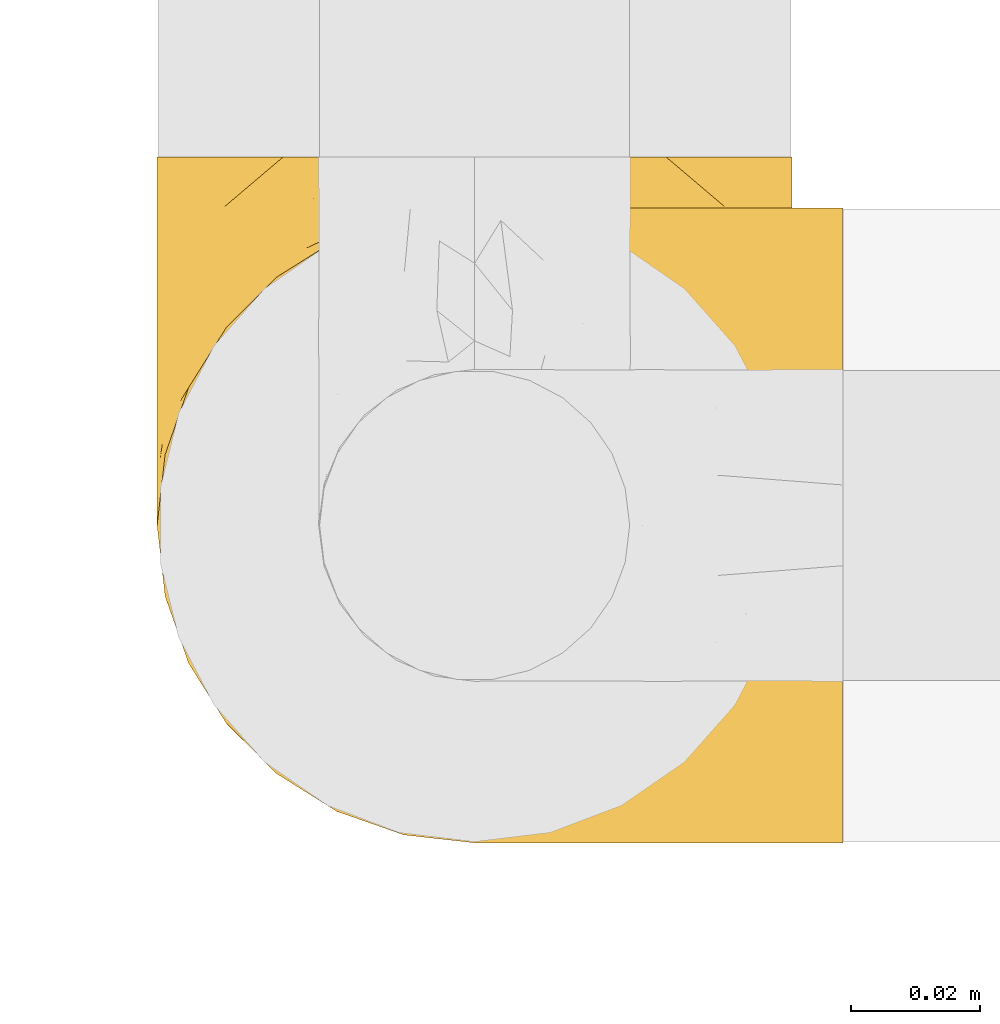
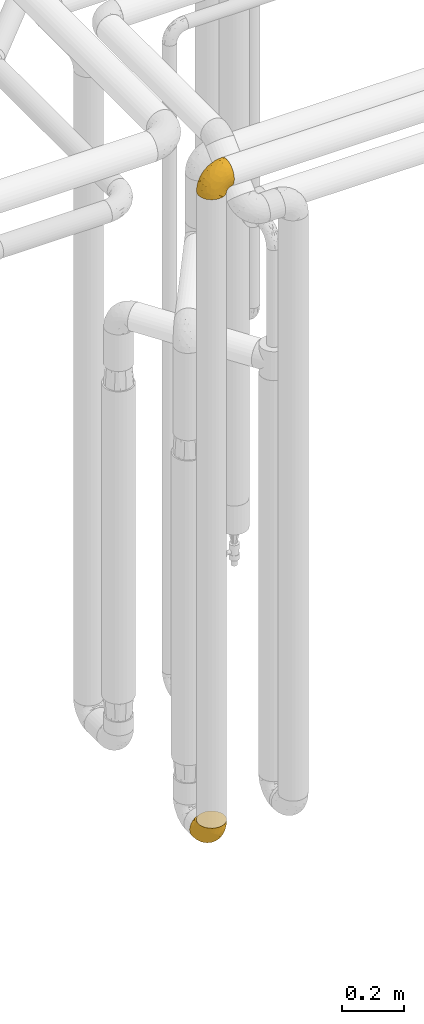
# One storey, part 381 of 827: 2 coverings.
"""IFC2X3 building model written with IfcOpenShell, lengths in millimetres."""

from ifc_helpers import new_model, entity, si_unit, converted_unit, derived_unit, direction, frame, origin, place, context, subcontext, project, spatial, faceted_brep, element, save


model = new_model("IFC2X3")

# Units and contexts
model_context = context("Model", 3, precision=0.01, world=origin(), true_north=direction((6.12303176911189e-17, 1.0)))
body_context = subcontext(model_context, "Body", "Model", "MODEL_VIEW")
ifc_project = project(units=[si_unit("LENGTHUNIT", "METRE", prefix="MILLI"), si_unit("AREAUNIT", "SQUARE_METRE"), si_unit("VOLUMEUNIT", "CUBIC_METRE"), converted_unit("PLANEANGLEUNIT", "DEGREE", entity("IfcRatioMeasure", 0.0174532925199433), si_unit("PLANEANGLEUNIT", "RADIAN"), dimensions=[0, 0, 0, 0, 0, 0, 0]), si_unit("MASSUNIT", "GRAM", prefix="KILO"), derived_unit("MASSDENSITYUNIT", [(si_unit("MASSUNIT", "GRAM", prefix="KILO"), 1), (si_unit("LENGTHUNIT", "METRE"), -3)]), derived_unit("MOMENTOFINERTIAUNIT", [(si_unit("LENGTHUNIT", "METRE"), 4)]), si_unit("TIMEUNIT", "SECOND"), si_unit("FREQUENCYUNIT", "HERTZ"), si_unit("THERMODYNAMICTEMPERATUREUNIT", "DEGREE_CELSIUS"), derived_unit("THERMALTRANSMITTANCEUNIT", [(si_unit("MASSUNIT", "GRAM", prefix="KILO"), 1), (si_unit("THERMODYNAMICTEMPERATUREUNIT", "KELVIN"), -1), (si_unit("TIMEUNIT", "SECOND"), -3)]), derived_unit("VOLUMETRICFLOWRATEUNIT", [(si_unit("LENGTHUNIT", "METRE"), 3), (si_unit("TIMEUNIT", "SECOND"), -1)]), derived_unit("MASSFLOWRATEUNIT", [(si_unit("MASSUNIT", "GRAM", prefix="KILO"), 1), (si_unit("TIMEUNIT", "SECOND"), -1)]), derived_unit("ROTATIONALFREQUENCYUNIT", [(si_unit("TIMEUNIT", "SECOND"), -1)]), si_unit("ELECTRICCURRENTUNIT", "AMPERE"), si_unit("ELECTRICVOLTAGEUNIT", "VOLT"), si_unit("POWERUNIT", "WATT"), si_unit("FORCEUNIT", "NEWTON", prefix="KILO"), si_unit("ILLUMINANCEUNIT", "LUX"), si_unit("LUMINOUSFLUXUNIT", "LUMEN"), si_unit("LUMINOUSINTENSITYUNIT", "CANDELA"), derived_unit("USERDEFINED", [(si_unit("MASSUNIT", "GRAM", prefix="KILO"), -1), (si_unit("LENGTHUNIT", "METRE"), -2), (si_unit("TIMEUNIT", "SECOND"), 3), (si_unit("LUMINOUSFLUXUNIT", "LUMEN"), 1)]), derived_unit("LINEARVELOCITYUNIT", [(si_unit("LENGTHUNIT", "METRE"), 1), (si_unit("TIMEUNIT", "SECOND"), -1)]), si_unit("PRESSUREUNIT", "PASCAL"), derived_unit("USERDEFINED", [(si_unit("LENGTHUNIT", "METRE"), -2), (si_unit("MASSUNIT", "GRAM", prefix="KILO"), 1), (si_unit("TIMEUNIT", "SECOND"), -2)]), derived_unit("LINEARFORCEUNIT", [(si_unit("MASSUNIT", "GRAM", prefix="KILO"), 1), (si_unit("LENGTHUNIT", "METRE"), 1), (si_unit("TIMEUNIT", "SECOND"), -2), (si_unit("LENGTHUNIT", "METRE"), -1)]), derived_unit("PLANARFORCEUNIT", [(si_unit("MASSUNIT", "GRAM", prefix="KILO"), 1), (si_unit("LENGTHUNIT", "METRE"), 1), (si_unit("TIMEUNIT", "SECOND"), -2), (si_unit("LENGTHUNIT", "METRE"), -2)])], contexts=[model_context])

# Site, building, storey
site_placement = place(None, origin())
site = spatial("IfcSite", under=ifc_project, at=site_placement, CompositionType="ELEMENT")
building_placement = place(site_placement, origin())
building = spatial("IfcBuilding", under=site, at=building_placement, CompositionType="ELEMENT")
storey_placement = place(building_placement, frame((0.0, 0.0, 28200.0)))
storey = spatial("IfcBuildingStorey", under=building, at=storey_placement, Name="08", CompositionType="ELEMENT", Elevation=28200.0)

# Coverings
covering_1_placement = place(storey_placement, frame((46642.04, 13586.09, 2941.4)))
element("IfcCovering", 1, at=covering_1_placement, inside=storey, Name=":ADSK_", ObjectType=":ADSK_", PredefinedType="INSULATION", context=body_context, shape_type="Brep", body=[
    faceted_brep([(50.75, 1.6, 1.6), (39.8, 2.83, 1.6), (29.41, 6.47, 1.6), (20.09, 12.32, 1.6), (12.31, 20.11, 1.6), (6.46, 29.43, 1.6), (2.83, 39.81, 1.6), (1.6, 50.75, 1.6), (2.83, 61.69, 1.6), (6.47, 72.08, 1.6), (12.32, 81.4, 1.6), (20.11, 89.18, 1.6), (29.43, 95.03, 1.6), (39.81, 98.66, 1.6), (50.75, 99.9, 1.6), (56.45, 99.25, 1.6), (61.69, 98.66, 1.6), (66.88, 96.84, 1.6), (72.08, 95.02, 1.6), (81.4, 89.17, 1.6), (89.18, 81.38, 1.6), (95.03, 72.06, 1.6), (98.66, 61.68, 1.6), (99.9, 50.75, 1.6), (98.66, 39.8, 1.6), (95.02, 29.41, 1.6), (89.17, 20.09, 1.6), (81.38, 12.31, 1.6), (72.06, 6.46, 1.6), (66.87, 4.64, 1.6), (61.68, 2.83, 1.6), (56.45, 2.24, 1.6), (53.6, 1.92, 1.6), (107.75, 63.47, 11.12), (107.75, 75.32, 16.03), (107.75, 80.41, 19.94), (107.75, 85.5, 23.84), (107.75, 89.4, 28.93), (107.75, 93.31, 34.02), (107.75, 95.77, 39.95), (107.75, 98.22, 45.87), (107.75, 99.14, 52.86), (107.75, 99.52, 55.73), (107.75, 99.9, 58.6), (107.75, 98.22, 71.32), (107.75, 93.31, 83.17), (107.75, 85.5, 93.35), (107.75, 75.32, 101.16), (107.75, 63.47, 106.07), (107.75, 50.75, 107.75), (107.75, 38.02, 106.07), (107.75, 26.17, 101.16), (107.75, 15.99, 93.35), (107.75, 8.18, 83.17), (107.75, 3.27, 71.32), (107.75, 1.6, 58.6), (107.75, 2.35, 52.86), (107.75, 3.27, 45.87), (107.75, 5.73, 39.95), (107.75, 8.18, 34.02), (107.75, 12.09, 28.93), (107.75, 15.99, 23.84), (107.75, 21.08, 19.94), (107.75, 26.17, 16.03), (107.75, 38.02, 11.12), (107.75, 50.75, 9.45), (39.38, 42.18, 81.82), (49.75, 28.42, 84.02), (57.38, 37.78, 93.05), (74.94, 50.75, 102.55), (85.97, 42.85, 104.83), (95.66, 50.75, 105.83), (67.82, 24.75, 91.87), (83.09, 33.81, 101.74), (89.16, 22.57, 97.07), (37.01, 7.18, 38.45), (43.46, 2.73, 22.17), (51.79, 3.09, 42.04), (85.58, 6.92, 77.69), (62.84, 11.58, 75.76), (62.77, 5.17, 62.11), (88.17, 2.71, 66.08), (85.93, 1.6, 54.26), (91.42, 1.6, 55.35), (96.91, 1.6, 56.44), (99.62, 1.6, 56.98), (102.33, 1.6, 57.52), (82.57, 14.18, 87.84), (32.75, 5.88, 19.41), (13.79, 41.06, 48.89), (6.77, 36.25, 26.34), (16.46, 28.62, 44.55), (55.08, 1.6, 23.41), (58.17, 1.6, 28.03), (61.26, 1.6, 32.65), (64.35, 1.6, 37.28), (67.44, 1.6, 41.9), (24.18, 10.85, 20.6), (23.37, 38.35, 63.36), (49.76, 9.6, 62.21), (9.84, 26.24, 19.94), (3.51, 50.75, 13.68), (55.75, 19.31, 80.85), (42.34, 16.41, 66.53), (37.78, 24.56, 71.06), (21.87, 50.75, 63.99), (33.61, 50.75, 75.73), (17.1, 18.47, 26.77), (51.28, 1.6, 4.31), (51.82, 1.6, 7.01), (52.9, 1.6, 12.43), (53.99, 1.6, 17.92), (28.01, 14.36, 43.43), (28.99, 20.64, 56.23), (69.9, 2.32, 54.97), (6.79, 50.75, 34.4), (72.06, 1.6, 44.99), (76.69, 1.6, 48.08), (81.31, 1.6, 51.17), (45.35, 50.75, 87.47), (34.79, 33.88, 74.55), (25.72, 29.24, 60.86), (14.33, 50.75, 49.19), (60.15, 50.75, 95.01), (62.38, 2.8, 10.27), (100.57, 2.48, 48.79), (91.06, 2.7, 45.16), (97.66, 3.2, 44.99), (97.55, 32.98, 6.17), (93.65, 24.67, 7.65), (66.85, 2.95, 21.59), (61.93, 2.19, 19.96), (101.4, 17.92, 21.0), (100.07, 12.02, 27.2), (101.36, 25.73, 14.83), (95.94, 16.63, 19.7), (96.3, 25.6, 10.93), (101.98, 36.72, 9.63), (85.88, 10.66, 19.97), (78.88, 6.87, 21.13), (82.8, 11.12, 14.14), (102.58, 10.31, 30.2), (82.88, 12.84, 8.12), (88.57, 17.38, 9.93), (88.67, 9.74, 24.62), (69.08, 4.63, 11.87), (102.19, 50.75, 7.15), (100.06, 42.52, 5.32), (70.56, 3.12, 26.68), (91.07, 17.58, 13.92), (77.56, 3.97, 30.67), (96.59, 5.94, 36.65), (86.38, 2.73, 42.89), (91.79, 6.23, 34.04), (81.71, 3.45, 36.6), (94.11, 10.84, 26.41), (76.09, 7.98, 10.07), (76.91, 7.33, 15.83), (81.44, 2.39, 41.99), (101.37, 75.76, 14.83), (94.12, 90.65, 26.4), (101.41, 83.57, 21.01), (95.96, 84.85, 19.71), (96.22, 71.05, 5.72), (66.85, 98.54, 21.6), (61.94, 99.3, 19.96), (58.17, 99.9, 28.03), (69.1, 96.86, 11.87), (88.58, 84.1, 9.93), (96.91, 99.9, 56.44), (102.33, 99.9, 57.52), (105.04, 99.9, 58.06), (82.9, 88.63, 8.13), (82.82, 90.36, 14.15), (97.66, 98.29, 44.99), (96.59, 95.55, 36.65), (100.07, 89.47, 27.21), (91.79, 95.26, 34.04), (102.58, 91.18, 30.2), (76.13, 93.49, 10.06), (76.93, 94.15, 15.83), (100.57, 99.01, 48.79), (86.38, 98.76, 42.89), (90.86, 98.85, 45.38), (52.9, 99.9, 12.43), (62.39, 98.69, 10.28), (101.98, 64.78, 9.64), (91.42, 99.9, 55.35), (85.93, 99.9, 54.26), (99.49, 62.91, 6.05), (51.82, 99.9, 7.01), (52.36, 99.9, 9.72), (61.26, 99.9, 32.65), (70.56, 98.37, 26.68), (91.09, 83.9, 13.92), (64.35, 99.9, 37.28), (77.6, 97.51, 30.66), (78.89, 94.62, 21.14), (81.71, 98.04, 36.59), (88.69, 91.73, 24.6), (53.99, 99.9, 17.92), (55.08, 99.9, 23.41), (96.31, 75.87, 10.93), (85.9, 90.83, 19.97), (81.45, 99.1, 41.99), (76.69, 99.9, 48.08), (81.31, 99.9, 51.17), (72.06, 99.9, 44.99), (67.44, 99.9, 41.9), (69.6, 99.09, 55.26), (85.97, 58.64, 104.83), (82.57, 87.31, 87.84), (63.16, 89.93, 75.91), (55.81, 82.22, 80.84), (67.81, 76.74, 91.87), (49.73, 73.12, 83.98), (32.55, 95.54, 19.16), (43.23, 98.7, 22.37), (88.17, 98.79, 66.08), (57.38, 63.71, 93.05), (83.08, 67.68, 101.74), (89.16, 78.92, 97.07), (85.58, 94.57, 77.69), (16.46, 72.88, 44.55), (6.77, 65.25, 26.34), (13.8, 60.44, 48.9), (37.71, 76.94, 70.99), (34.8, 67.61, 74.55), (36.83, 94.38, 37.8), (39.38, 59.31, 81.82), (17.12, 83.03, 26.77), (24.19, 90.66, 20.6), (28.89, 80.8, 56.15), (25.69, 72.22, 60.85), (51.77, 98.39, 42.06), (45.66, 92.31, 57.03), (23.39, 63.11, 63.4), (9.85, 75.27, 19.94), (28.11, 87.15, 43.59), (62.27, 96.03, 62.61), (42.35, 85.1, 66.52)], [[[0, 1, 2, 3, 4, 5, 6, 7, 8, 9, 10, 11, 12, 13, 14, 15, 16, 17, 18, 19, 20, 21, 22, 23, 24, 25, 26, 27, 28, 29, 30, 31, 32]], [[33, 34, 35, 36, 37, 38, 39, 40, 41, 42, 43, 44, 45, 46, 47, 48, 49, 50, 51, 52, 53, 54, 55, 56, 57, 58, 59, 60, 61, 62, 63, 64, 65]], [[66, 67, 68]], [[69, 70, 71]], [[68, 72, 73]], [[73, 72, 74]], [[75, 76, 77]], [[78, 79, 80]], [[51, 50, 73]], [[81, 82, 83, 84, 85, 86, 55]], [[52, 87, 53]], [[74, 52, 51]], [[2, 1, 88]], [[89, 90, 91]], [[77, 92, 93, 94, 95, 96]], [[55, 54, 81]], [[78, 53, 87]], [[5, 90, 6]], [[88, 76, 75]], [[97, 3, 2]], [[89, 91, 98]], [[99, 80, 79]], [[90, 5, 100]], [[74, 87, 52]], [[100, 5, 4]], [[90, 101, 6]], [[79, 102, 103]], [[102, 67, 104]], [[105, 98, 106]], [[107, 4, 3]], [[76, 0, 108, 109, 110, 111, 92]], [[107, 112, 113]], [[114, 77, 96]], [[89, 115, 90]], [[114, 96, 116, 117, 118, 82]], [[75, 97, 88]], [[119, 66, 68]], [[50, 71, 70]], [[100, 91, 90]], [[99, 77, 80]], [[102, 104, 103]], [[97, 107, 3]], [[80, 81, 78]], [[107, 97, 112]], [[68, 73, 70]], [[66, 98, 120]], [[78, 81, 54]], [[114, 81, 80]], [[53, 78, 54]], [[78, 87, 79]], [[102, 87, 72]], [[79, 103, 99]], [[4, 107, 100]], [[91, 100, 107]], [[88, 97, 2]], [[112, 97, 75]], [[99, 112, 75]], [[103, 104, 113]], [[91, 121, 98]], [[89, 105, 122, 115]], [[101, 90, 115]], [[101, 7, 6]], [[88, 1, 76]], [[0, 76, 1]], [[92, 77, 76]], [[73, 74, 51]], [[87, 74, 72]], [[81, 114, 82]], [[77, 114, 80]], [[87, 102, 79]], [[67, 102, 72]], [[68, 67, 72]], [[67, 120, 104]], [[120, 121, 104]], [[104, 121, 113]], [[121, 120, 98]], [[91, 107, 113]], [[91, 113, 121]], [[103, 113, 112]], [[106, 98, 66]], [[105, 89, 98]], [[106, 66, 119]], [[67, 66, 120]], [[68, 69, 123, 119]], [[50, 49, 71]], [[50, 70, 73]], [[112, 99, 103]], [[77, 99, 75]], [[69, 68, 70]], [[29, 124, 110]], [[84, 83, 125]], [[126, 82, 118]], [[59, 58, 127]], [[25, 128, 129]], [[130, 93, 131]], [[132, 62, 133]], [[134, 135, 136]], [[137, 65, 64]], [[64, 134, 137]], [[138, 139, 140]], [[111, 110, 124, 92]], [[134, 136, 137]], [[134, 64, 63]], [[141, 61, 60]], [[125, 58, 57]], [[142, 143, 140]], [[142, 26, 143]], [[127, 83, 82]], [[28, 124, 29]], [[108, 0, 32, 31, 30, 110, 109]], [[30, 29, 110]], [[135, 144, 138]], [[28, 145, 124]], [[57, 56, 55, 86, 85, 84]], [[146, 147, 23]], [[24, 23, 147]], [[25, 143, 26]], [[95, 94, 148]], [[24, 128, 25]], [[149, 138, 143]], [[124, 145, 131]], [[127, 58, 125]], [[150, 148, 139]], [[127, 126, 151]], [[151, 59, 127]], [[152, 151, 126]], [[153, 154, 155]], [[153, 133, 141]], [[145, 28, 27]], [[142, 156, 27]], [[157, 148, 130]], [[61, 133, 62]], [[134, 132, 135]], [[147, 128, 24]], [[65, 137, 146]], [[146, 137, 147]], [[128, 137, 136]], [[137, 128, 147]], [[128, 136, 129]], [[149, 129, 136]], [[25, 129, 143]], [[158, 152, 117]], [[152, 118, 117]], [[153, 151, 152]], [[158, 116, 154]], [[144, 150, 138]], [[153, 152, 158]], [[133, 153, 155]], [[133, 155, 132]], [[60, 151, 141]], [[135, 132, 155]], [[134, 63, 132]], [[144, 135, 155]], [[135, 138, 149]], [[155, 154, 144]], [[150, 154, 96]], [[154, 150, 144]], [[148, 94, 130]], [[82, 126, 127]], [[118, 152, 126]], [[150, 96, 95]], [[139, 148, 157]], [[150, 95, 148]], [[93, 92, 131]], [[130, 145, 156]], [[130, 94, 93]], [[84, 125, 57]], [[127, 125, 83]], [[140, 139, 157]], [[150, 139, 138]], [[140, 157, 142]], [[138, 140, 143]], [[156, 142, 157]], [[27, 26, 142]], [[130, 156, 157]], [[145, 27, 156]], [[132, 63, 62]], [[124, 131, 92]], [[130, 131, 145]], [[129, 149, 143]], [[135, 149, 136]], [[141, 133, 61]], [[60, 59, 151]], [[141, 151, 153]], [[116, 96, 154]], [[153, 158, 154]], [[158, 117, 116]], [[34, 33, 159]], [[160, 161, 162]], [[22, 21, 163]], [[164, 165, 166]], [[19, 18, 167]], [[168, 21, 20]], [[42, 41, 40, 169, 170, 171, 43]], [[172, 173, 168]], [[174, 38, 175]], [[176, 177, 178]], [[179, 164, 180]], [[40, 181, 169]], [[182, 183, 175]], [[17, 184, 185]], [[65, 146, 186]], [[187, 174, 188]], [[23, 22, 189]], [[174, 39, 38]], [[15, 14, 190, 191, 184, 16]], [[181, 40, 39]], [[192, 193, 164]], [[194, 163, 168]], [[33, 186, 159]], [[180, 173, 172]], [[195, 196, 193]], [[18, 185, 167]], [[173, 180, 197]], [[198, 199, 196]], [[200, 201, 185, 184]], [[184, 17, 16]], [[18, 17, 185]], [[202, 159, 186]], [[194, 168, 203]], [[189, 163, 202]], [[204, 205, 182]], [[187, 181, 174]], [[160, 177, 176]], [[206, 183, 182]], [[206, 182, 205]], [[201, 165, 185]], [[165, 164, 167]], [[172, 179, 180]], [[202, 194, 162]], [[176, 161, 160]], [[65, 186, 33]], [[163, 189, 22]], [[175, 177, 182]], [[174, 183, 188]], [[177, 198, 204]], [[199, 160, 162]], [[198, 207, 204]], [[175, 38, 37]], [[198, 177, 160]], [[178, 177, 175]], [[176, 35, 161]], [[34, 159, 161]], [[162, 161, 159]], [[202, 162, 159]], [[199, 162, 203]], [[196, 199, 203]], [[198, 160, 199]], [[193, 197, 180]], [[208, 198, 196]], [[188, 183, 206]], [[175, 183, 174]], [[193, 192, 195]], [[195, 208, 196]], [[197, 196, 203]], [[180, 164, 193]], [[168, 163, 21]], [[166, 165, 201]], [[166, 192, 164]], [[189, 202, 186]], [[186, 146, 189]], [[23, 189, 146]], [[174, 181, 39]], [[169, 181, 187]], [[196, 197, 193]], [[173, 203, 168]], [[203, 173, 197]], [[172, 168, 20]], [[20, 19, 172]], [[179, 172, 19]], [[19, 167, 179]], [[164, 179, 167]], [[35, 176, 36]], [[35, 34, 161]], [[185, 165, 167]], [[162, 194, 203]], [[163, 194, 202]], [[176, 178, 36]], [[37, 36, 178]], [[175, 37, 178]], [[177, 204, 182]], [[207, 198, 208]], [[207, 205, 204]], [[209, 188, 206, 205, 207, 208]], [[48, 210, 71]], [[211, 212, 213]], [[214, 213, 215]], [[216, 217, 13]], [[218, 43, 171, 170, 169, 187, 188]], [[219, 220, 214]], [[47, 46, 221]], [[210, 48, 220]], [[211, 222, 212]], [[222, 45, 44]], [[221, 220, 47]], [[47, 220, 48]], [[221, 211, 214]], [[223, 224, 225]], [[211, 46, 45]], [[226, 227, 215]], [[43, 218, 44]], [[217, 216, 228]], [[219, 215, 229]], [[14, 13, 217]], [[224, 9, 8]], [[10, 230, 11]], [[11, 231, 12]], [[232, 223, 233]], [[234, 208, 195, 192, 166, 201]], [[235, 234, 228]], [[222, 44, 218]], [[106, 229, 236]], [[224, 237, 9]], [[231, 238, 228]], [[9, 237, 10]], [[115, 224, 101]], [[239, 234, 235]], [[231, 11, 230]], [[223, 230, 237]], [[224, 8, 101]], [[223, 236, 233]], [[225, 115, 122, 105]], [[216, 12, 231]], [[209, 234, 239]], [[210, 219, 69]], [[219, 214, 215]], [[229, 119, 219]], [[209, 218, 188]], [[239, 212, 222]], [[239, 222, 218]], [[45, 222, 211]], [[235, 212, 239]], [[213, 212, 240]], [[223, 237, 224]], [[230, 10, 237]], [[238, 231, 230]], [[216, 231, 228]], [[232, 230, 223]], [[235, 238, 240]], [[115, 225, 224]], [[233, 236, 227]], [[8, 7, 101]], [[234, 209, 208]], [[218, 209, 239]], [[217, 228, 234]], [[13, 12, 216]], [[234, 201, 217]], [[217, 201, 200, 184, 191, 190, 14]], [[211, 221, 46]], [[220, 221, 214]], [[71, 210, 69]], [[71, 49, 48]], [[219, 210, 220]], [[226, 215, 213]], [[211, 213, 214]], [[226, 213, 240]], [[215, 227, 229]], [[232, 240, 238]], [[233, 227, 226]], [[232, 233, 226]], [[236, 223, 225]], [[240, 232, 226]], [[232, 238, 230]], [[225, 105, 236]], [[236, 105, 106]], [[236, 229, 227]], [[123, 69, 219, 119]], [[106, 119, 229]], [[238, 235, 228]], [[212, 235, 240]]]),
])
covering_2_placement = place(storey_placement, frame((46642.04, 13586.09, 349.25)))
element("IfcCovering", 2, at=covering_2_placement, inside=storey, Name=":ADSK_", ObjectType=":ADSK_", PredefinedType="INSULATION", context=body_context, shape_type="Brep", body=[
    faceted_brep([(1.6, 50.75, 107.75), (2.83, 39.8, 107.75), (6.47, 29.41, 107.75), (12.32, 20.09, 107.75), (20.11, 12.31, 107.75), (29.43, 6.46, 107.75), (39.81, 2.83, 107.75), (50.75, 1.6, 107.75), (61.69, 2.83, 107.75), (72.08, 6.47, 107.75), (81.4, 12.32, 107.75), (89.18, 20.11, 107.75), (95.03, 29.43, 107.75), (98.66, 39.81, 107.75), (99.9, 50.75, 107.75), (99.25, 56.45, 107.75), (98.66, 61.69, 107.75), (96.84, 66.88, 107.75), (95.02, 72.08, 107.75), (89.17, 81.4, 107.75), (81.38, 89.18, 107.75), (72.06, 95.03, 107.75), (61.68, 98.66, 107.75), (50.75, 99.9, 107.75), (39.8, 98.66, 107.75), (29.41, 95.02, 107.75), (20.09, 89.17, 107.75), (12.31, 81.38, 107.75), (6.46, 72.06, 107.75), (4.64, 66.87, 107.75), (2.83, 61.68, 107.75), (2.24, 56.45, 107.75), (1.92, 53.6, 107.75), (63.47, 107.75, 98.22), (75.32, 107.75, 93.31), (80.41, 107.75, 89.4), (85.5, 107.75, 85.5), (89.4, 107.75, 80.41), (93.31, 107.75, 75.32), (95.77, 107.75, 69.39), (98.22, 107.75, 63.47), (99.14, 107.75, 56.48), (99.52, 107.75, 53.61), (99.9, 107.75, 50.75), (98.22, 107.75, 38.02), (93.31, 107.75, 26.17), (85.5, 107.75, 15.99), (75.32, 107.75, 8.18), (63.47, 107.75, 3.27), (50.75, 107.75, 1.6), (38.02, 107.75, 3.27), (26.17, 107.75, 8.18), (15.99, 107.75, 15.99), (8.18, 107.75, 26.17), (3.27, 107.75, 38.02), (1.6, 107.75, 50.75), (2.35, 107.75, 56.48), (3.27, 107.75, 63.47), (5.73, 107.75, 69.39), (8.18, 107.75, 75.32), (12.09, 107.75, 80.41), (15.99, 107.75, 85.5), (21.08, 107.75, 89.4), (26.17, 107.75, 93.31), (38.02, 107.75, 98.22), (50.75, 107.75, 99.9), (42.18, 39.38, 27.53), (28.42, 49.75, 25.32), (37.78, 57.38, 16.29), (50.75, 74.94, 6.79), (42.85, 85.97, 4.51), (50.75, 95.66, 3.51), (24.75, 67.82, 17.47), (33.81, 83.09, 7.6), (22.57, 89.16, 12.27), (7.18, 37.01, 70.89), (2.73, 43.46, 87.17), (3.09, 51.79, 67.3), (6.92, 85.58, 31.65), (11.58, 62.84, 33.58), (5.17, 62.77, 47.23), (2.71, 88.17, 43.26), (1.6, 85.93, 55.08), (1.6, 91.42, 53.99), (1.6, 96.91, 52.9), (1.6, 99.62, 52.36), (1.6, 102.33, 51.82), (14.18, 82.57, 21.5), (5.88, 32.75, 89.94), (41.06, 13.79, 60.45), (36.25, 6.77, 83.0), (28.62, 16.46, 64.79), (1.6, 55.08, 85.93), (1.6, 58.17, 81.31), (1.6, 61.26, 76.69), (1.6, 64.35, 72.06), (1.6, 67.44, 67.44), (10.85, 24.18, 88.74), (38.35, 23.37, 45.98), (9.6, 49.76, 47.13), (26.24, 9.84, 89.4), (50.75, 3.51, 95.66), (19.31, 55.75, 28.5), (16.41, 42.34, 42.81), (24.56, 37.78, 38.28), (50.75, 21.87, 45.35), (50.75, 33.61, 33.61), (18.47, 17.1, 82.57), (1.6, 51.28, 105.04), (1.6, 51.82, 102.33), (1.6, 52.9, 96.91), (1.6, 53.99, 91.42), (14.36, 28.01, 65.92), (20.64, 28.99, 53.11), (2.32, 69.9, 54.37), (50.75, 6.79, 74.94), (1.6, 72.06, 64.35), (1.6, 76.69, 61.26), (1.6, 81.31, 58.17), (50.75, 45.35, 21.87), (33.88, 34.79, 34.79), (29.24, 25.72, 48.48), (50.75, 14.33, 60.15), (50.75, 60.15, 14.33), (2.8, 62.38, 99.07), (2.48, 100.57, 60.55), (2.7, 91.06, 64.18), (3.2, 97.66, 64.36), (32.98, 97.55, 103.17), (24.67, 93.65, 101.69), (2.95, 66.85, 87.75), (2.19, 61.93, 89.38), (17.92, 101.4, 88.34), (12.02, 100.07, 82.14), (25.73, 101.36, 94.51), (16.63, 95.94, 89.64), (25.6, 96.3, 98.41), (36.72, 101.98, 99.71), (10.66, 85.88, 89.37), (6.87, 78.88, 88.21), (11.12, 82.8, 95.2), (10.31, 102.58, 79.14), (12.84, 82.88, 101.22), (17.38, 88.57, 99.41), (9.74, 88.67, 84.72), (4.63, 69.08, 97.47), (50.75, 102.19, 102.19), (42.52, 100.06, 104.02), (3.12, 70.56, 82.66), (17.58, 91.07, 95.42), (3.97, 77.56, 78.67), (5.94, 96.59, 72.69), (2.73, 86.38, 66.46), (6.23, 91.79, 75.3), (3.45, 81.71, 72.74), (10.84, 94.11, 82.93), (7.98, 76.09, 99.27), (7.33, 76.91, 93.51), (2.39, 81.44, 67.35), (75.76, 101.37, 94.51), (90.65, 94.12, 82.94), (83.57, 101.41, 88.33), (84.85, 95.96, 89.64), (71.05, 96.22, 103.62), (98.54, 66.85, 87.74), (99.3, 61.94, 89.38), (99.9, 58.17, 81.31), (96.86, 69.1, 97.47), (84.1, 88.58, 99.41), (99.9, 96.91, 52.9), (99.9, 102.33, 51.82), (99.9, 105.04, 51.28), (88.63, 82.9, 101.21), (90.36, 82.82, 95.19), (98.29, 97.66, 64.36), (95.55, 96.59, 72.69), (89.47, 100.07, 82.13), (95.26, 91.79, 75.3), (91.18, 102.58, 79.14), (93.49, 76.13, 99.28), (94.15, 76.93, 93.51), (99.01, 100.57, 60.55), (98.76, 86.38, 66.46), (98.85, 90.86, 63.96), (99.9, 52.9, 96.91), (98.69, 62.39, 99.06), (64.78, 101.98, 99.7), (99.9, 91.42, 53.99), (99.9, 85.93, 55.08), (62.91, 99.49, 103.3), (99.9, 51.82, 102.33), (99.9, 52.36, 99.62), (99.9, 61.26, 76.69), (98.37, 70.56, 82.66), (83.9, 91.09, 95.42), (99.9, 64.35, 72.06), (97.51, 77.6, 78.68), (94.62, 78.89, 88.2), (98.04, 81.71, 72.75), (91.73, 88.69, 84.74), (99.9, 53.99, 91.42), (99.9, 55.08, 85.93), (75.87, 96.31, 98.41), (90.83, 85.9, 89.37), (99.1, 81.45, 67.35), (99.9, 76.69, 61.26), (99.9, 81.31, 58.17), (99.9, 72.06, 64.35), (99.9, 67.44, 67.44), (99.09, 69.6, 54.08), (58.64, 85.97, 4.51), (87.31, 82.57, 21.5), (89.93, 63.16, 33.43), (82.22, 55.81, 28.5), (76.74, 67.81, 17.47), (73.12, 49.73, 25.36), (95.54, 32.55, 90.18), (98.7, 43.23, 86.97), (98.79, 88.17, 43.26), (63.71, 57.38, 16.29), (67.68, 83.08, 7.6), (78.92, 89.16, 12.27), (94.57, 85.58, 31.65), (72.88, 16.46, 64.79), (65.25, 6.77, 83.0), (60.44, 13.8, 60.44), (76.94, 37.71, 38.35), (67.61, 34.8, 34.8), (94.38, 36.83, 71.54), (59.31, 39.38, 27.53), (83.03, 17.12, 82.57), (90.66, 24.19, 88.74), (80.8, 28.89, 53.19), (72.22, 25.69, 48.49), (98.39, 51.77, 67.28), (92.31, 45.66, 52.32), (63.11, 23.39, 45.94), (75.27, 9.85, 89.4), (87.15, 28.11, 65.75), (96.03, 62.27, 46.73), (85.1, 42.35, 42.82)], [[[0, 1, 2, 3, 4, 5, 6, 7, 8, 9, 10, 11, 12, 13, 14, 15, 16, 17, 18, 19, 20, 21, 22, 23, 24, 25, 26, 27, 28, 29, 30, 31, 32]], [[33, 34, 35, 36, 37, 38, 39, 40, 41, 42, 43, 44, 45, 46, 47, 48, 49, 50, 51, 52, 53, 54, 55, 56, 57, 58, 59, 60, 61, 62, 63, 64, 65]], [[66, 67, 68]], [[69, 70, 71]], [[68, 72, 73]], [[73, 72, 74]], [[75, 76, 77]], [[78, 79, 80]], [[51, 50, 73]], [[81, 82, 83, 84, 85, 86, 55]], [[52, 87, 53]], [[74, 52, 51]], [[2, 1, 88]], [[89, 90, 91]], [[77, 92, 93, 94, 95, 96]], [[55, 54, 81]], [[78, 53, 87]], [[5, 90, 6]], [[88, 76, 75]], [[97, 3, 2]], [[89, 91, 98]], [[99, 80, 79]], [[90, 5, 100]], [[74, 87, 52]], [[100, 5, 4]], [[90, 101, 6]], [[79, 102, 103]], [[102, 67, 104]], [[105, 98, 106]], [[107, 4, 3]], [[76, 0, 108, 109, 110, 111, 92]], [[107, 112, 113]], [[114, 77, 96]], [[89, 115, 90]], [[114, 96, 116, 117, 118, 82]], [[75, 97, 88]], [[119, 66, 68]], [[50, 71, 70]], [[100, 91, 90]], [[99, 77, 80]], [[102, 104, 103]], [[97, 107, 3]], [[80, 81, 78]], [[107, 97, 112]], [[68, 73, 70]], [[66, 98, 120]], [[78, 81, 54]], [[114, 81, 80]], [[53, 78, 54]], [[78, 87, 79]], [[102, 87, 72]], [[79, 103, 99]], [[4, 107, 100]], [[91, 100, 107]], [[88, 97, 2]], [[112, 97, 75]], [[99, 112, 75]], [[103, 104, 113]], [[91, 121, 98]], [[89, 105, 122, 115]], [[101, 90, 115]], [[101, 7, 6]], [[88, 1, 76]], [[0, 76, 1]], [[92, 77, 76]], [[73, 74, 51]], [[87, 74, 72]], [[81, 114, 82]], [[77, 114, 80]], [[87, 102, 79]], [[67, 102, 72]], [[68, 67, 72]], [[67, 120, 104]], [[120, 121, 104]], [[104, 121, 113]], [[121, 120, 98]], [[91, 107, 113]], [[91, 113, 121]], [[103, 113, 112]], [[106, 98, 66]], [[105, 89, 98]], [[106, 66, 119]], [[67, 66, 120]], [[68, 69, 123, 119]], [[50, 49, 71]], [[50, 70, 73]], [[112, 99, 103]], [[77, 99, 75]], [[69, 68, 70]], [[29, 124, 110]], [[84, 83, 125]], [[126, 82, 118]], [[59, 58, 127]], [[25, 128, 129]], [[130, 93, 131]], [[132, 62, 133]], [[134, 135, 136]], [[137, 65, 64]], [[64, 134, 137]], [[138, 139, 140]], [[111, 110, 124, 92]], [[134, 136, 137]], [[134, 64, 63]], [[141, 61, 60]], [[125, 58, 57]], [[142, 143, 140]], [[142, 26, 143]], [[127, 83, 82]], [[28, 124, 29]], [[108, 0, 32, 31, 30, 110, 109]], [[30, 29, 110]], [[135, 144, 138]], [[28, 145, 124]], [[57, 56, 55, 86, 85, 84]], [[146, 147, 23]], [[24, 23, 147]], [[25, 143, 26]], [[95, 94, 148]], [[24, 128, 25]], [[149, 138, 143]], [[124, 145, 131]], [[127, 58, 125]], [[150, 148, 139]], [[127, 126, 151]], [[151, 59, 127]], [[152, 151, 126]], [[153, 154, 155]], [[153, 133, 141]], [[145, 28, 27]], [[142, 156, 27]], [[157, 148, 130]], [[61, 133, 62]], [[134, 132, 135]], [[147, 128, 24]], [[65, 137, 146]], [[146, 137, 147]], [[128, 137, 136]], [[137, 128, 147]], [[128, 136, 129]], [[149, 129, 136]], [[25, 129, 143]], [[158, 152, 117]], [[152, 118, 117]], [[153, 151, 152]], [[158, 116, 154]], [[144, 150, 138]], [[153, 152, 158]], [[133, 153, 155]], [[133, 155, 132]], [[60, 151, 141]], [[135, 132, 155]], [[134, 63, 132]], [[144, 135, 155]], [[135, 138, 149]], [[155, 154, 144]], [[150, 154, 96]], [[154, 150, 144]], [[148, 94, 130]], [[82, 126, 127]], [[118, 152, 126]], [[150, 96, 95]], [[139, 148, 157]], [[150, 95, 148]], [[93, 92, 131]], [[130, 145, 156]], [[130, 94, 93]], [[84, 125, 57]], [[127, 125, 83]], [[140, 139, 157]], [[150, 139, 138]], [[140, 157, 142]], [[138, 140, 143]], [[156, 142, 157]], [[27, 26, 142]], [[130, 156, 157]], [[145, 27, 156]], [[132, 63, 62]], [[124, 131, 92]], [[130, 131, 145]], [[129, 149, 143]], [[135, 149, 136]], [[141, 133, 61]], [[60, 59, 151]], [[141, 151, 153]], [[116, 96, 154]], [[153, 158, 154]], [[158, 117, 116]], [[34, 33, 159]], [[160, 161, 162]], [[22, 21, 163]], [[164, 165, 166]], [[19, 18, 167]], [[168, 21, 20]], [[42, 41, 40, 169, 170, 171, 43]], [[172, 173, 168]], [[174, 38, 175]], [[176, 177, 178]], [[179, 164, 180]], [[40, 181, 169]], [[182, 183, 175]], [[17, 184, 185]], [[65, 146, 186]], [[187, 174, 188]], [[23, 22, 189]], [[174, 39, 38]], [[15, 14, 190, 191, 184, 16]], [[181, 40, 39]], [[192, 193, 164]], [[194, 163, 168]], [[33, 186, 159]], [[180, 173, 172]], [[195, 196, 193]], [[18, 185, 167]], [[173, 180, 197]], [[198, 199, 196]], [[200, 201, 185, 184]], [[184, 17, 16]], [[18, 17, 185]], [[202, 159, 186]], [[194, 168, 203]], [[189, 163, 202]], [[204, 205, 182]], [[187, 181, 174]], [[160, 177, 176]], [[206, 183, 182]], [[206, 182, 205]], [[201, 165, 185]], [[165, 164, 167]], [[172, 179, 180]], [[202, 194, 162]], [[176, 161, 160]], [[65, 186, 33]], [[163, 189, 22]], [[175, 177, 182]], [[174, 183, 188]], [[177, 198, 204]], [[199, 160, 162]], [[198, 207, 204]], [[175, 38, 37]], [[198, 177, 160]], [[178, 177, 175]], [[176, 35, 161]], [[34, 159, 161]], [[162, 161, 159]], [[202, 162, 159]], [[199, 162, 203]], [[196, 199, 203]], [[198, 160, 199]], [[193, 197, 180]], [[208, 198, 196]], [[188, 183, 206]], [[175, 183, 174]], [[193, 192, 195]], [[195, 208, 196]], [[197, 196, 203]], [[180, 164, 193]], [[168, 163, 21]], [[166, 165, 201]], [[166, 192, 164]], [[189, 202, 186]], [[186, 146, 189]], [[23, 189, 146]], [[174, 181, 39]], [[169, 181, 187]], [[196, 197, 193]], [[173, 203, 168]], [[203, 173, 197]], [[172, 168, 20]], [[20, 19, 172]], [[179, 172, 19]], [[19, 167, 179]], [[164, 179, 167]], [[35, 176, 36]], [[35, 34, 161]], [[185, 165, 167]], [[162, 194, 203]], [[163, 194, 202]], [[176, 178, 36]], [[37, 36, 178]], [[175, 37, 178]], [[177, 204, 182]], [[207, 198, 208]], [[207, 205, 204]], [[209, 188, 206, 205, 207, 208]], [[48, 210, 71]], [[211, 212, 213]], [[214, 213, 215]], [[216, 217, 13]], [[218, 43, 171, 170, 169, 187, 188]], [[219, 220, 214]], [[47, 46, 221]], [[210, 48, 220]], [[211, 222, 212]], [[222, 45, 44]], [[221, 220, 47]], [[47, 220, 48]], [[221, 211, 214]], [[223, 224, 225]], [[211, 46, 45]], [[226, 227, 215]], [[43, 218, 44]], [[217, 216, 228]], [[219, 215, 229]], [[14, 13, 217]], [[224, 9, 8]], [[10, 230, 11]], [[11, 231, 12]], [[232, 223, 233]], [[234, 208, 195, 192, 166, 201]], [[235, 234, 228]], [[222, 44, 218]], [[106, 229, 236]], [[224, 237, 9]], [[231, 238, 228]], [[9, 237, 10]], [[115, 224, 101]], [[239, 234, 235]], [[231, 11, 230]], [[223, 230, 237]], [[224, 8, 101]], [[223, 236, 233]], [[225, 115, 122, 105]], [[216, 12, 231]], [[209, 234, 239]], [[210, 219, 69]], [[219, 214, 215]], [[229, 119, 219]], [[209, 218, 188]], [[239, 212, 222]], [[239, 222, 218]], [[45, 222, 211]], [[235, 212, 239]], [[213, 212, 240]], [[223, 237, 224]], [[230, 10, 237]], [[238, 231, 230]], [[216, 231, 228]], [[232, 230, 223]], [[235, 238, 240]], [[115, 225, 224]], [[233, 236, 227]], [[8, 7, 101]], [[234, 209, 208]], [[218, 209, 239]], [[217, 228, 234]], [[13, 12, 216]], [[234, 201, 217]], [[217, 201, 200, 184, 191, 190, 14]], [[211, 221, 46]], [[220, 221, 214]], [[71, 210, 69]], [[71, 49, 48]], [[219, 210, 220]], [[226, 215, 213]], [[211, 213, 214]], [[226, 213, 240]], [[215, 227, 229]], [[232, 240, 238]], [[233, 227, 226]], [[232, 233, 226]], [[236, 223, 225]], [[240, 232, 226]], [[232, 238, 230]], [[225, 105, 236]], [[236, 105, 106]], [[236, 229, 227]], [[123, 69, 219, 119]], [[106, 119, 229]], [[238, 235, 228]], [[212, 235, 240]]]),
])

save(model, "model.ifc")
